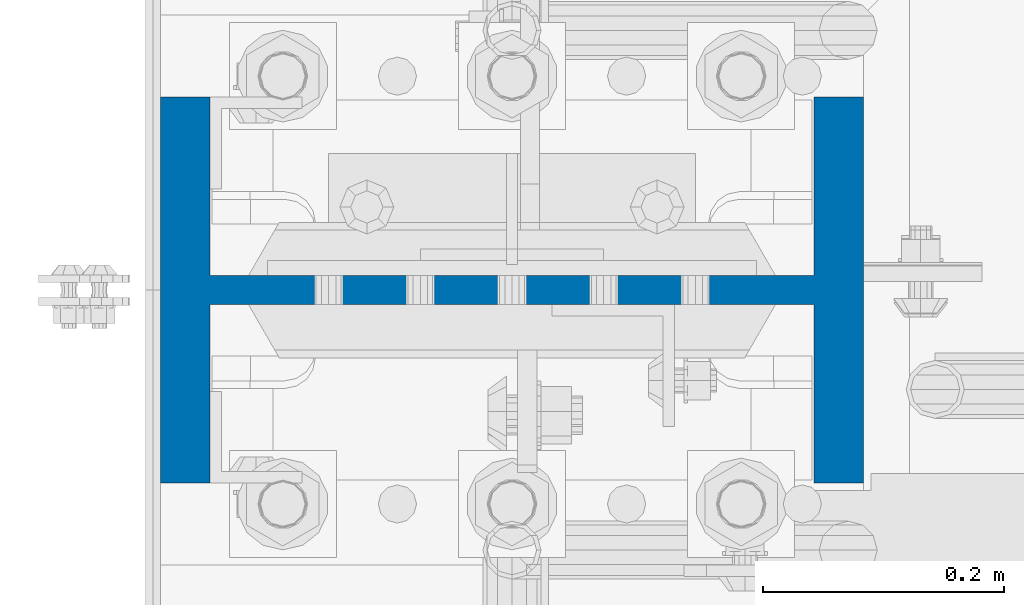
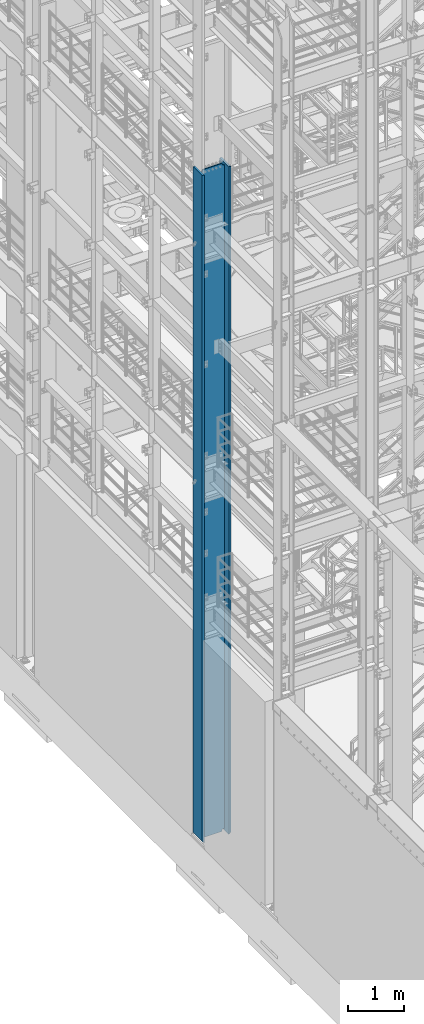
# One storey, part 600 of 1876: 1 column, 1 element without a shape of its own.
"""IFC2X3 building model written with IfcOpenShell, lengths in millimetres."""

from ifc_helpers import new_model, si_unit, frame, origin_with_axes, place, context, subcontext, project, spatial, faceted_brep, material, type_object, element, aggregate, save


model = new_model("IFC2X3")

# Units and contexts
model_context = context("Model", 3, precision=1e-05, world=origin_with_axes())
body_context = subcontext(model_context, "Body", "Model", "MODEL_VIEW")
ifc_project = project(units=[si_unit("LENGTHUNIT", "METRE", prefix="MILLI"), si_unit("AREAUNIT", "SQUARE_METRE"), si_unit("VOLUMEUNIT", "CUBIC_METRE"), si_unit("MASSUNIT", "GRAM", prefix="KILO"), si_unit("TIMEUNIT", "SECOND"), si_unit("PLANEANGLEUNIT", "RADIAN"), si_unit("SOLIDANGLEUNIT", "STERADIAN"), si_unit("THERMODYNAMICTEMPERATUREUNIT", "DEGREE_CELSIUS"), si_unit("LUMINOUSINTENSITYUNIT", "LUMEN")], contexts=[model_context])

# Site, building, storey
site_placement = place(None, origin_with_axes())
site = spatial("IfcSite", under=ifc_project, at=site_placement, CompositionType="ELEMENT")
building_placement = place(site_placement, origin_with_axes())
building = spatial("IfcBuilding", under=site, at=building_placement, Name="Undefined", CompositionType="ELEMENT")
storey_placement = place(building_placement, origin_with_axes())
storey = spatial("IfcBuildingStorey", under=building, at=storey_placement, Name="Undefined", CompositionType="ELEMENT", Elevation=0.0)

# Assembly, column
assembly_placement = place(storey_placement, origin_with_axes())
assembly = element("IfcElementAssembly", 1, at=assembly_placement, inside=storey, Name="COLUMN", AssemblyPlace="NOTDEFINED", PredefinedType="RIGID_FRAME")
ifc_material = material(Name="STEEL/A992")
column_type = type_object("IfcColumnType", Name="W21X201", PredefinedType="NOTDEFINED")
column_placement = place(assembly_placement, frame((0.0, -4572.0, 0.0), z_axis=(-1.0, 0.0, 0.0), x_axis=(0.0, 0.0, 1.0)))
column = element("IfcColumn", 2, at=column_placement, type_object=column_type, material=ifc_material, Name="COLUMN", ObjectType="W21X201", context=body_context, shape_type="Brep", body=[
    faceted_brep([(112.712499999999, 11.90625, 200.025000762939), (112.712499999999, 11.90625, -200.025000762939), (88.9, -11.90625, -200.025000762939), (88.9, -11.90625, 200.025000762939), (14528.8, -160.3375, 292.1), (14528.8, 160.3375, 292.1), (130.174999999997, 160.3375, 292.1), (130.175, -160.3375, 292.099999999999), (139.700000000013, -160.3375, 250.825), (14478.0, -160.3375, 250.825), (14528.8, -160.3375, 250.825), (88.9, -160.3375, 250.825), (139.700000000013, -11.90625, 250.825), (14478.0, -11.90625, 250.825), (14528.8, -11.90625, 250.825), (88.9, -11.90625, 250.825), (14528.8, -160.3375, -292.1), (14528.8, -160.3375, -250.825), (14478.0000007629, -160.3375, -250.825), (139.700000000013, -160.3375, -250.825), (88.9, -160.3375, -250.825), (130.175000825646, -160.3375, -292.100000825653), (14528.8, 160.3375, -292.1), (130.175000825646, 160.3375, -292.1), (139.700000000013, 160.3375, -250.825), (14478.0000007629, 160.3375, -250.825), (14528.8, 160.3375, -250.825), (88.9, 160.3375, -250.825), (14528.8, 11.90625, -250.825), (14528.8, -11.90625, -250.825), (14478.0000007629, -11.90625, -250.825), (139.700000000013, -11.90625, -250.825), (88.9, -11.90625, -250.825), (114.300000381483, -11.90625, -200.025000762939), (114.300000381483, 11.90625, -200.025000762939), (124.020159417574, 11.90625, -201.958460608115), (124.020159417574, -11.90625, -201.958460608115), (132.260512353882, 11.90625, -207.464488409071), (132.260512353882, -11.90625, -207.464488409071), (137.766540154838, 11.90625, -215.704841345379), (137.766540154838, -11.90625, -215.704841345379), (139.700000000013, 11.90625, -225.42500038147), (139.700000000013, -11.90625, -225.42500038147), (139.700000000013, 11.90625, -250.825), (88.9, 11.90625, -250.825), (14478.0000007629, 11.90625, -250.825), (14481.8669204533, 11.90625, -231.384681927819), (14481.8669204533, -11.90625, -231.384681927819), (14492.8789760552, 11.90625, -214.903976055204), (14492.8789760552, -11.90625, -214.903976055204), (14509.3596819278, 11.90625, -203.891920453291), (14509.3596819278, -11.90625, -203.891920453291), (14528.8, -11.90625, -200.02500076294), (14528.8, 11.90625, -200.02500076294), (14528.8, 11.90625, 200.02500076294), (14528.8, -11.90625, 200.02500076294), (14509.3596811649, 11.90625, 203.891920453291), (14509.3596811649, -11.90625, 203.891920453291), (14492.8789752923, 11.90625, 214.903976055204), (14492.8789752923, -11.90625, 214.903976055204), (14481.8669196904, 11.90625, 231.384681927819), (14481.8669196904, -11.90625, 231.384681927819), (14478.0, 11.90625, 250.825), (14528.8, 11.90625, 250.825), (14528.8, 160.3375, 250.825), (14478.0, 160.3375, 250.825), (139.700000000013, 160.3375, 250.825), (88.9, 160.3375, 250.825), (88.9, 11.90625, 250.825), (139.700000000013, 11.90625, 250.825), (139.700000000013, 11.90625, 225.42500038147), (139.700000000013, -11.90625, 225.42500038147), (137.766540154838, 11.90625, 215.704841345379), (137.766540154838, -11.90625, 215.704841345379), (132.260512353882, 11.90625, 207.464488409071), (132.260512353882, -11.90625, 207.464488409071), (124.020159417574, 11.90625, 201.958460608115), (124.020159417574, -11.90625, 201.958460608115), (114.300000381483, 11.90625, 200.025000762939), (114.300000381483, -11.90625, 200.025000762939)], [[[0, 1, 2, 3]], [[4, 5, 6, 7]], [[8, 9, 10, 4, 7, 11]], [[12, 13, 14, 10, 9, 8, 11, 15]], [[16, 17, 18, 19, 20, 21]], [[22, 16, 21, 23]], [[24, 25, 26, 22, 23, 27]], [[17, 16, 22, 26, 28, 29]], [[19, 18, 17, 29, 30, 31, 32, 20]], [[33, 34, 35, 36]], [[36, 35, 37, 38]], [[38, 37, 39, 40]], [[40, 39, 41, 42]], [[42, 41, 43, 31]], [[31, 43, 44, 32]], [[27, 23, 21, 20, 32, 44]], [[43, 45, 28, 26, 25, 24, 27, 44]], [[29, 28, 45, 30]], [[30, 45, 46, 47]], [[47, 46, 48, 49]], [[49, 48, 50, 51]], [[52, 51, 50, 53]], [[54, 55, 52, 53]], [[55, 54, 56, 57]], [[57, 56, 58, 59]], [[59, 58, 60, 61]], [[61, 60, 62, 13]], [[14, 13, 62, 63]], [[64, 5, 4, 10, 14, 63]], [[5, 64, 65, 66, 67, 6]], [[11, 7, 6, 67, 68, 15]], [[66, 65, 64, 63, 62, 69, 68, 67]], [[15, 68, 69, 12]], [[12, 69, 70, 71]], [[71, 70, 72, 73]], [[73, 72, 74, 75]], [[75, 74, 76, 77]], [[77, 76, 78, 79]], [[79, 78, 0, 3]], [[33, 36, 38, 40, 42, 31, 30, 47, 49, 51, 52, 55, 57, 59, 61, 13, 12, 71, 73, 75, 77, 79, 3, 2]], [[34, 33, 2, 1]], [[78, 76, 74, 72, 70, 69, 62, 60, 58, 56, 54, 53, 50, 48, 46, 45, 43, 41, 39, 37, 35, 34, 1, 0]]]),
])
aggregate(assembly, [column])

save(model, "model.ifc")
